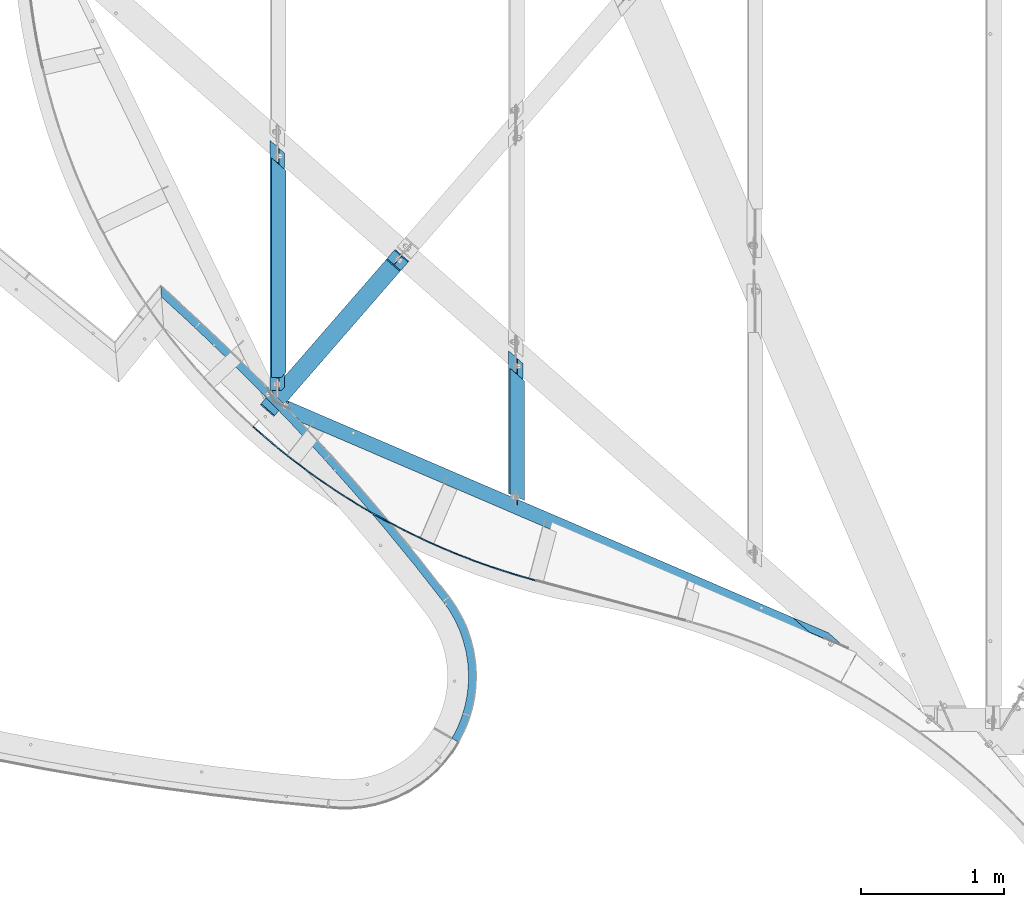
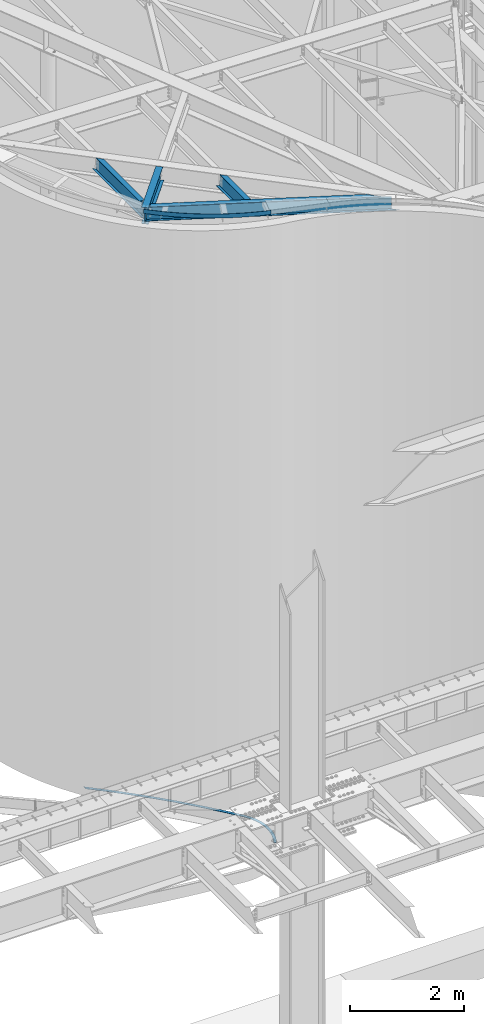
# One storey, part 1148 of 1763: 6 beams, 5 elements without a shape of their own.
"""IFC2X3 building model written with IfcOpenShell, lengths in millimetres."""

from ifc_helpers import new_model, si_unit, frame, origin_with_axes, place, context, subcontext, project, spatial, faceted_brep, material, type_object, element, aggregate, save


model = new_model("IFC2X3")

# Units and contexts
model_context = context("Model", 3, precision=1e-05, world=origin_with_axes())
body_context = subcontext(model_context, "Body", "Model", "MODEL_VIEW")
ifc_project = project(units=[si_unit("LENGTHUNIT", "METRE", prefix="MILLI"), si_unit("AREAUNIT", "SQUARE_METRE"), si_unit("VOLUMEUNIT", "CUBIC_METRE"), si_unit("MASSUNIT", "GRAM", prefix="KILO"), si_unit("TIMEUNIT", "SECOND"), si_unit("PLANEANGLEUNIT", "RADIAN"), si_unit("SOLIDANGLEUNIT", "STERADIAN"), si_unit("THERMODYNAMICTEMPERATUREUNIT", "DEGREE_CELSIUS"), si_unit("LUMINOUSINTENSITYUNIT", "LUMEN")], contexts=[model_context])

# Site, building, storey
site_placement = place(None, origin_with_axes())
site = spatial("IfcSite", under=ifc_project, at=site_placement, CompositionType="ELEMENT")
building_placement = place(site_placement, origin_with_axes())
building = spatial("IfcBuilding", under=site, at=building_placement, Name="Undefined", CompositionType="ELEMENT")
storey_placement = place(building_placement, origin_with_axes())
storey = spatial("IfcBuildingStorey", under=building, at=storey_placement, Name="Undefined", CompositionType="ELEMENT", Elevation=0.0)

# Assembly, beam
assembly_1_placement = place(storey_placement, origin_with_axes())
assembly_1 = element("IfcElementAssembly", 1, at=assembly_1_placement, inside=storey, Name="PLATE", AssemblyPlace="NOTDEFINED", PredefinedType="RIGID_FRAME")
ifc_material_1 = material(Name="STEEL/A36")
beam_type_1 = type_object("IfcBeamType", PredefinedType="NOTDEFINED")
beam_1_placement = place(assembly_1_placement, frame((-46769.9138544958, 57631.4044649229, -3.17499999999491), z_axis=(0.97359968730827, -0.228262237072275, 0.0), x_axis=(0.228262231888325, 0.973599688523656, 0.0)))
beam_1 = element("IfcBeam", 2, at=beam_1_placement, type_object=beam_type_1, material=ifc_material_1, Name="PLATE", context=body_context, shape_type="Brep", body=[
    faceted_brep([(22.7999745803754, -3.17500001063642, -24.5256942961641), (6.15889249815518, -3.175, 30.1478540359603), (-8.84756445884705e-09, 9.69761293490023e-09, 28.5749999999134), (16.6410820689634, -1.58744351885787e-07, -26.0985483375407), (1534.03549039258, 3.18245254706104, -1087.78632156259), (1723.28957115061, 3.18493668133378, -1356.83887718113), (1723.28775202866, -3.16506293471967, -1356.84012894642), (1534.03414568807, -3.16754723696902, -1087.78728830347), (1339.27698435845, 3.17996838873531, -822.69104558714), (1339.27610136085, -3.17003151527805, -822.691708418584), (2473.27803125291, 3.15512548669445, -2441.90225550858), (2634.42711592402, 3.15264106502508, -2730.02312585434), (2567.22163278471, 3.19087219085719, -2708.95851937175), (2473.27419921351, -3.1948729775194, -2441.90445094836), (2634.42275489638, -3.19735699124559, -2730.02550635775), (2423.68593715149, -3.15512548669445, -2470.31439965982), (2423.68976919089, 3.1948729775194, -2470.31220422004), (2555.03166728665, 3.19690478077967, -2705.14034993343), (2555.02490536015, -3.15309338839345, -2705.13823194704), (2306.22559311581, 3.15760988451737, -2157.16352860411), (2306.22228038139, -3.19238893964634, -2157.16551830514), (2257.23001704671, -3.15760988451737, -2186.59134749896), (2257.23332978112, 3.19238893964635, -2186.58935779794), (2133.34075431278, 3.16009425847506, -1875.92788281315), (2133.33795057509, -3.18990487764521, -1875.92964642501), (2084.96249500642, -3.16009425847506, -1906.35885788099), (2084.96529874411, 3.18990487764521, -1906.35709426913), (1954.69694485167, 3.16257860854875, -1598.31476793136), (1954.69463918676, -3.18742079153477, -1598.31628544521), (1906.95653843257, -3.16257860854875, -1629.73595475013), (1906.95884409747, 3.18742079153477, -1629.73443723627), (1770.37004075991, 3.16506293471967, -1324.44209514365), (1770.36822163795, -3.18493668133378, -1324.44334690894), (1580.43698715287, -3.18245254706104, -1054.42715368434), (1580.43833185737, 3.16754723696902, -1054.42618694347), (1384.98160550654, -3.17996838873531, -788.382390558436), (1384.98248850414, 3.17003151527805, -788.381727726999), (80.7582906747048, -3.175, 49.1990007622007), (163.054713896541, -3.175, 62.410724488509), (163.054713896541, 3.175, 62.410724488509), (80.7582906747048, 3.175, 49.1990007622007), (246.21040849424, -3.175, 68.1011879935031), (246.21040849424, 3.175, 68.1011879935031), (329.53942518049, -3.175, 66.2234507831599), (329.53942518049, 3.175, 66.2234507831599), (412.354384938299, -3.175, 56.7930022657092), (412.354384938299, 3.175, 56.7930022657092), (493.972149193702, -3.175, 39.8876339799172), (493.972149193702, 3.175, 39.8876339799172), (573.719455009086, -3.175, 15.6467978945875), (573.719455009086, 3.175, 15.6467978945875), (650.938468812681, -3.175, -15.7295439273657), (650.938468812681, 3.175, -15.7295439273657), (724.99221285159, -3.175, -53.9825688109995), (724.99221285159, 3.175, -53.9825688109995), (795.269819605637, -3.175, -98.7967284912957), (795.269819605637, 3.175, -98.7967284912957), (861.191570818606, -3.175, -149.802352063052), (861.191570818606, 3.175, -149.802352063052), (922.213679579894, -3.175, -206.578695387136), (922.213679579894, 3.175, -206.578695387136), (977.832776009454, -3.175, -268.657411798536), (977.832776009454, 3.175, -268.657411798536), (933.579880992431, 3.175, -304.820981625016), (881.424431994536, 3.175, -246.608181786556), (824.202440168767, 3.175, -193.367552782773), (762.385928323762, 3.175, -145.538275257975), (696.484819351157, 3.175, -103.514891750594), (627.042729884219, 3.175, -67.6440521215482), (554.632486017545, 3.175, -38.2216540480586), (479.85139807863, 3.175, -15.4904021709517), (403.316333429677, 3.175, 0.362193969995133), (325.658627943769, 3.175, 9.20536669759895), (247.51887813073, 3.175, 10.9661688967099), (169.541656872279, 3.175, 5.63007575312804), (92.3701963560234, 3.175, -6.75889543153608), (16.6410820689634, 3.175, -26.0985483375407), (7.52334017306566e-09, 3.175, 28.5749999998952), (1139.09677348819, 3.17748420637537, -561.665643672444), (1184.085527337, 3.17251576962797, -526.421715082877), (1184.08509276175, -3.17748420637537, -526.422055526607), (933.579880992533, -3.175, -304.820981625126), (1139.09633891293, -3.17251576962797, -561.665984116167), (881.424431994536, -3.175, -246.608181786556), (824.202440168767, -3.175, -193.367552782773), (762.385928323762, -3.175, -145.538275257975), (696.484819351157, -3.175, -103.514891750594), (627.042729884219, -3.175, -67.6440521215482), (554.632486017545, -3.175, -38.2216540480586), (479.85139807863, -3.175, -15.4904021709517), (403.316333429677, -3.175, 0.362193969995133), (325.658627943769, -3.175, 9.20536669759895), (247.51887813073, -3.175, 10.9661688967099), (169.541656872279, -3.175, 5.63007575312804), (92.3701963560234, -3.175, -6.75889543153608)], [[[0, 1, 2, 3]], [[4, 5, 6, 7]], [[8, 4, 7, 9]], [[10, 11, 12]], [[10, 13, 14, 11]], [[13, 15, 14]], [[15, 16, 17, 18]], [[15, 18, 14]], [[17, 12, 11, 14, 18]], [[16, 19, 10, 12, 17]], [[20, 13, 10, 19]], [[20, 21, 13]], [[15, 13, 21]], [[22, 16, 15, 21]], [[19, 16, 22, 23]], [[24, 20, 19, 23]], [[24, 25, 20]], [[21, 20, 25]], [[26, 22, 21, 25]], [[23, 22, 26, 27]], [[28, 24, 23, 27]], [[28, 29, 24]], [[25, 24, 29]], [[30, 26, 25, 29]], [[27, 26, 30, 31]], [[32, 28, 27, 31]], [[33, 32, 31, 34]], [[35, 33, 34, 36]], [[35, 9, 33]], [[7, 33, 9]], [[33, 7, 32]], [[6, 32, 7]], [[32, 6, 28]], [[29, 28, 6]], [[5, 30, 29, 6]], [[31, 30, 5, 34]], [[4, 34, 5]], [[34, 4, 36]], [[8, 36, 4]], [[37, 38, 39, 40]], [[38, 41, 42, 39]], [[41, 43, 44, 42]], [[43, 45, 46, 44]], [[45, 47, 48, 46]], [[47, 49, 50, 48]], [[49, 51, 52, 50]], [[51, 53, 54, 52]], [[53, 55, 56, 54]], [[55, 57, 58, 56]], [[57, 59, 60, 58]], [[59, 61, 62, 60]], [[39, 42, 44, 46, 48, 50, 52, 54, 56, 58, 60, 62, 63, 64, 65, 66, 67, 68, 69, 70, 71, 72, 73, 74, 75, 76, 77, 40]], [[63, 62, 78]], [[79, 78, 62]], [[78, 79, 8]], [[36, 8, 79]], [[80, 35, 36, 79]], [[62, 61, 80, 79]], [[61, 81, 80]], [[82, 80, 81]], [[80, 82, 35]], [[9, 35, 82]], [[78, 8, 9, 82]], [[81, 63, 78, 82]], [[64, 63, 81, 83]], [[65, 64, 83, 84]], [[66, 65, 84, 85]], [[67, 66, 85, 86]], [[68, 67, 86, 87]], [[69, 68, 87, 88]], [[70, 69, 88, 89]], [[71, 70, 89, 90]], [[72, 71, 90, 91]], [[73, 72, 91, 92]], [[74, 73, 92, 93]], [[75, 74, 93, 94]], [[76, 75, 94, 0, 3]], [[77, 76, 3, 2]], [[37, 40, 77, 2, 1]], [[94, 93, 92, 91, 90, 89, 88, 87, 86, 85, 84, 83, 81, 61, 59, 57, 55, 53, 51, 49, 47, 45, 43, 41, 38, 37, 1, 0]]]),
])
aggregate(assembly_1, [beam_1])

assembly_2_placement = place(storey_placement, origin_with_axes())
assembly_2 = element("IfcElementAssembly", 3, at=assembly_2_placement, inside=storey, Name="BEAM", AssemblyPlace="NOTDEFINED", PredefinedType="RIGID_FRAME")
beam_type_2 = type_object("IfcBeamType", PredefinedType="NOTDEFINED")
beam_2_placement = place(assembly_2_placement, frame((-46201.735896308, 58755.4652369062, 12670.1493063058), z_axis=(0.0256066577239253, -0.0139122708500072, 0.999575283708039), x_axis=(-0.878314523638845, 0.477194242803782, 0.0291419319880167)))
beam_2 = element("IfcBeam", 4, at=beam_2_placement, type_object=beam_type_2, material=ifc_material_1, Name="PLATE", context=body_context, shape_type="Brep", body=[
    faceted_brep([(-0.743652594275773, 3.08668200803731, -44.4499999999807), (-0.743652593984734, 3.08668200816464, 44.4499999999734), (110.044294424864, 28.3962885762667, 44.4499999998861), (110.044294424573, 28.396288576143, -44.4500000000662), (0.743652594304876, -3.08668200806278, 44.4499999999771), (0.743652594013838, -3.08668200819375, -44.4499999999771), (111.385248448016, 22.1894905041081, -44.4500000000626), (111.385248448321, 22.1894905042318, 44.4499999998898), (221.399589052598, 51.0798453443822, 44.4499999998006), (221.399589052322, 51.0798453442549, -44.4500000001517), (222.593442443249, 44.8430822350056, -44.4500000001481), (222.593442443555, 44.8430822351402, 44.4499999998043), (333.259994112843, 71.1246743295815, 44.449999999717), (333.259994112552, 71.1246743294651, -44.4500000002336), (334.306079618793, 64.8614319492262, -44.4500000002317), (334.306079619098, 64.8614319493499, 44.4499999997224), (445.562990119724, 88.5195723505421, 44.4499999996351), (445.562990119433, 88.5195723504221, -44.4500000003172), (446.460723077224, 82.2333512648656, -44.45000000031), (446.460723077515, 82.2333512649966, 44.4499999996406), (558.245810220615, 103.254817289071, 44.4499999995569), (558.245810220324, 103.254817288936, -44.4500000003973), (558.994688881008, 96.9491309066725, -44.45000000039), (558.994688881314, 96.9491309067926, 44.4499999995624), (671.245475276693, 115.322173523811, 44.4499999994787), (671.245475276402, 115.322173523688, -44.4500000004737), (671.845081086998, 109.000546132596, -44.4500000004664), (671.845081087289, 109.00054613272, 44.4499999994841), (784.498829062562, 124.714896533296, 44.4499999994041), (784.498829062286, 124.714896533173, -44.4500000005482), (784.948826899345, 118.380861330668, -44.4500000005428), (784.948826899621, 118.380861330796, 44.4499999994077), (897.942573564622, 131.427736665395, 44.4499999993295), (897.942573564331, 131.427736665271, -44.4500000006228), (898.242711921179, 125.084833783574, -44.4500000006192), (898.24271192147, 125.084833783698, 44.4499999993332), (1011.5133043586, 135.456942071418, 44.4499999992586), (1011.5133043583, 135.456942071294, -44.4500000006919), (1011.66341548577, 129.108716598817, -44.4500000006883), (1011.66341548607, 129.108716598948, 44.4499999992622), (1125.14754604688, 136.800260803062, 44.4499999991876), (1125.1475460466, 136.800260802935, -44.4500000007647), (1125.14754604659, 130.450260802936, -44.4500000007592), (1125.14754604688, 130.450260803063, 44.4499999991931), (1238.78178773516, 135.456942071007, 44.4499999991203), (1238.78178773486, 135.456942070883, -44.4500000008338), (1238.63167660739, 129.108716598406, -44.4500000008265), (1238.63167660768, 129.108716598537, 44.4499999991258), (1352.35251852912, 131.427736664569, 44.4499999990549), (1352.35251852883, 131.427736664446, -44.4500000008957), (1352.05238017197, 125.084833782741, -44.450000000892), (1352.05238017224, 125.084833782876, 44.4499999990603), (1465.79626303115, 124.714896532067, 44.449999998993), (1465.79626303088, 124.714896531947, -44.4500000009612), (1465.34626519377, 118.380861329431, -44.4500000009557), (1465.34626519408, 118.380861329562, 44.4499999989966), (1579.04961681701, 115.322173522174, 44.4499999989312), (1579.04961681672, 115.32217352205, -44.4500000010212), (1578.45001100609, 109.000546130956, -44.4500000010157), (1578.45001100638, 109.000546131083, 44.4499999989348), (1692.04928187307, 103.254817287012, 44.4499999988711), (1692.04928187277, 103.254817286892, -44.4500000010812), (1691.30040321204, 96.9491309046243, -44.4500000010739), (1691.30040321233, 96.949130904748, 44.4499999988766), (1804.73210197387, 88.5195723480865, 44.4499999988147), (1804.73210197358, 88.5195723479628, -44.4500000011376), (1803.83436901578, 82.23335126241, -44.4500000011321), (1803.83436901607, 82.2333512625373, 44.4499999988202), (1917.03509798071, 71.1246743267184, 44.4499999987602), (1917.03509798042, 71.1246743265947, -44.4500000011922), (1915.98901247414, 64.8614319463668, -44.4500000011867), (1915.98901247444, 64.8614319464905, 44.4499999987675), (2028.89550304088, 51.079845341108, 44.4499999987092), (2028.89550304058, 51.079845340988, -44.4500000012431), (2027.70164964961, 44.8430822317423, -44.4500000012376), (2027.7016496499, 44.8430822318696, 44.4499999987129), (2140.25079766854, 28.3962885725959, 44.4499999986583), (2140.25079766825, 28.396288572465, -44.4500000012958), (2138.90984364478, 22.189490500441, -44.4500000012904), (2138.90984364507, 22.1894905005684, 44.4499999986638), (2251.03874468731, 3.08668200409011, 44.449999998611), (2251.038744687, 3.08668200396642, -44.4500000013413), (2249.551439499, -3.08668201213004, 44.4499999986165), (2249.55143949871, -3.08668201226101, -44.4500000013359)], [[[0, 1, 2, 3]], [[4, 5, 6, 7]], [[5, 4, 1, 0]], [[3, 2, 8, 9]], [[7, 6, 10, 11]], [[9, 8, 12, 13]], [[11, 10, 14, 15]], [[13, 12, 16, 17]], [[15, 14, 18, 19]], [[17, 16, 20, 21]], [[19, 18, 22, 23]], [[21, 20, 24, 25]], [[23, 22, 26, 27]], [[25, 24, 28, 29]], [[27, 26, 30, 31]], [[29, 28, 32, 33]], [[31, 30, 34, 35]], [[33, 32, 36, 37]], [[35, 34, 38, 39]], [[37, 36, 40, 41]], [[39, 38, 42, 43]], [[41, 40, 44, 45]], [[43, 42, 46, 47]], [[45, 44, 48, 49]], [[47, 46, 50, 51]], [[49, 48, 52, 53]], [[51, 50, 54, 55]], [[53, 52, 56, 57]], [[55, 54, 58, 59]], [[57, 56, 60, 61]], [[59, 58, 62, 63]], [[61, 60, 64, 65]], [[63, 62, 66, 67]], [[65, 64, 68, 69]], [[67, 66, 70, 71]], [[69, 68, 72, 73]], [[71, 70, 74, 75]], [[73, 72, 76, 77]], [[75, 74, 78, 79]], [[77, 76, 80, 81]], [[76, 72, 68, 64, 60, 56, 52, 48, 44, 40, 36, 32, 28, 24, 20, 16, 12, 8, 2, 1, 4, 7, 11, 15, 19, 23, 27, 31, 35, 39, 43, 47, 51, 55, 59, 63, 67, 71, 75, 79, 82, 80]], [[79, 78, 83, 82]], [[78, 74, 70, 66, 62, 58, 54, 50, 46, 42, 38, 34, 30, 26, 22, 18, 14, 10, 6, 5, 0, 3, 9, 13, 17, 21, 25, 29, 33, 37, 41, 45, 49, 53, 57, 61, 65, 69, 73, 77, 81, 83]], [[82, 83, 81, 80]]]),
])

assembly_3_placement = place(storey_placement, origin_with_axes())
assembly_3 = element("IfcElementAssembly", 5, at=assembly_3_placement, inside=storey, Name="BEAM", AssemblyPlace="NOTDEFINED", PredefinedType="RIGID_FRAME")
ifc_material_2 = material(Name="STEEL/A992")
beam_type_3 = type_object("IfcBeamType", Name="W14X22", PredefinedType="NOTDEFINED")
beam_3_placement = place(assembly_3_placement, frame((-48079.991922386, 59946.7082810739, 12529.1066598258), z_axis=(0.0172511022173494, 0.0198445932500254, 0.999654236019149), x_axis=(0.655842160335249, 0.75443995938565, -0.0262946460134414)))
beam_3 = element("IfcBeam", 6, at=beam_3_placement, type_object=beam_type_3, material=ifc_material_2, Name="BEAM", ObjectType="W14X22", context=body_context, shape_type="Brep", body=[
    faceted_brep([(1342.53638462444, -63.500000000844, 166.687499999865), (1342.54200190829, -3.17500000086147, 166.687499999816), (1342.54259320133, 3.17499999914435, 166.687499999811), (1342.54821048519, 63.4999999991269, 166.68749999976), (1334.23658565302, 63.4999999991123, 174.624999999754), (1334.22475979227, -63.500000000844, 174.624999999864), (1317.14256125842, -3.17500000083237, 166.687499999818), (1317.14315255146, 3.1749999991589, 166.687499999811), (1301.57934423534, -3.17500000080327, 154.834291783058), (1301.57993552838, 3.174999999188, 154.834307337342), (1298.56088115037, -3.17500000080327, 150.099209506028), (1298.56147244341, 3.174999999188, 150.09922506031), (1298.73444332104, -3.17500000078871, 144.486545285426), (1298.73503461407, 3.17499999921711, 144.486560839709), (1302.03970819279, -3.17500000077416, 139.947013625022), (1302.04029948583, 3.17499999921711, 139.947029179302), (1307.32791149423, -3.17500000078871, 138.058355487427), (1307.32850278726, 3.17499999921711, 138.058371041709), (1421.89722715088, -3.17500000083237, 138.824126773025), (1421.89781844392, 3.1749999991589, 138.824142327307), (1429.1769288343, -3.1750000003376, -138.090483327867), (1429.17752012734, 3.17499999965366, -138.090467773585), (1403.3300335189, -3.1750000003376, -138.26324271675), (1403.33062481194, 3.17499999965366, -138.263227162466), (1397.78114954089, -3.17500000032305, -140.228942113727), (1397.78174083393, 3.17499999968277, -140.228926559445), (1394.44741611587, -3.1750000003085, -145.080777725503), (1394.44800740891, 3.17499999969732, -145.080762171221), (1394.60220520838, -3.17500000029395, -150.965514557867), (1394.60279650141, 3.17499999969732, -150.965499003585), (1398.1863926877, -3.1750000003085, -155.635384734467), (1398.18698398074, 3.17499999969732, -155.635369180187), (1413.23260548103, -3.1750000002794, -166.687499999993), (1413.23319677408, 3.17499999969732, -166.6875), (1429.94989342443, -3.17500000029395, -166.687499999995), (1429.95048471748, 3.17499999969732, -166.687499999998), (1438.01743337284, -63.5000000002765, -174.62499999994), (1438.02957450544, 63.4999999996944, -174.625000000045), (1429.95610200133, 63.4999999996799, -166.687500000049), (1429.94427614058, -63.5000000002765, -166.687499999944), (2.20097717829049e-10, -63.4999999996799, -174.624999999842), (2.03726813197136e-10, -63.4999999996944, -166.687499999845), (3.27418092638254e-10, -3.17499999971187, -166.687499999898), (-3.12866177409887e-10, -3.1750000003085, 166.687499999909), (-4.32919478043914e-10, -63.500000000291, 166.687499999958), (-4.52928361482918e-10, -63.500000000291, 174.624999999953), (-2.00088834390044e-10, 63.4999999996799, 174.624999999845), (-1.81898940354586e-10, 63.4999999996799, 166.687499999851), (-3.01952240988612e-10, 3.17499999969732, 166.687499999904), (3.36513039655983e-10, 3.17500000029395, -166.687499999904), (4.63842297904193e-10, 63.5000000002765, -166.687499999953), (4.80213202536106e-10, 63.500000000291, -174.624999999949), (1413.22698819718, -63.5000000002619, -166.687499999944), (1317.13694397456, -63.5000000008149, 166.687499999869), (1317.14876983531, 63.499999999156, 166.68749999976), (1413.23881405793, 63.4999999996799, -166.687500000051)], [[[0, 1, 2, 3, 4, 5]], [[6, 7, 2, 1]], [[8, 9, 7, 6]], [[10, 11, 9, 8]], [[12, 13, 11, 10]], [[14, 15, 13, 12]], [[16, 17, 15, 14]], [[18, 19, 17, 16]], [[20, 21, 19, 18]], [[22, 23, 21, 20]], [[24, 25, 23, 22]], [[26, 27, 25, 24]], [[28, 29, 27, 26]], [[30, 31, 29, 28]], [[32, 33, 31, 30]], [[34, 35, 33, 32]], [[36, 37, 38, 35, 34, 39]], [[40, 41, 42, 43, 44, 45, 46, 47, 48, 49, 50, 51]], [[52, 41, 40, 36, 39]], [[32, 42, 41, 52, 39, 34]], [[16, 14, 12, 10, 8, 6, 43, 42, 32, 30, 28, 26, 24, 22, 20, 18]], [[53, 44, 43, 6, 1, 0]], [[45, 44, 53, 0, 5]], [[46, 45, 5, 4]], [[54, 47, 46, 4, 3]], [[7, 48, 47, 54, 3, 2]], [[25, 27, 29, 31, 33, 49, 48, 7, 9, 11, 13, 15, 17, 19, 21, 23]], [[55, 50, 49, 33, 35, 38]], [[51, 50, 55, 38, 37]], [[40, 51, 37, 36]]]),
])
aggregate(assembly_3, [beam_3])

assembly_4_placement = place(storey_placement, origin_with_axes())
assembly_4 = element("IfcElementAssembly", 7, at=assembly_4_placement, inside=storey, Name="BEAM", AssemblyPlace="NOTDEFINED", PredefinedType="RIGID_FRAME")
beam_type_4 = type_object("IfcBeamType", Name="W12X16", PredefinedType="NOTDEFINED")
beam_4_placement = place(assembly_4_placement, frame((-46340.5472371989, 59268.7374006593, 12489.8609543434), z_axis=(0.0294363099980619, 0.0, 0.999566657934176), x_axis=(0.0, 1.0, 0.0)))
beam_4 = element("IfcBeam", 8, at=beam_4_placement, type_object=beam_type_4, material=ifc_material_2, Name="BEAM", ObjectType="W12X16", context=body_context, shape_type="Brep", body=[
    faceted_brep([(60.2082465235726, 3.17499999981374, -117.295703353439), (57.4846154797779, -3.17500000019209, -117.295703353453), (18.4558559940342, -3.17500000018481, -117.295703362503), (21.1794870360318, 3.17499999982101, -117.295703362481), (65.4594476598868, 3.17499999982101, -118.248378752771), (62.7358166160921, -3.17500000018481, -118.248378752785), (69.9228235650589, 3.17499999981374, -120.96347732625), (67.1991925212642, -3.17500000019209, -120.963477326266), (72.9287445552836, 3.17499999980646, -125.033659284922), (70.2051135114889, -3.17500000019936, -125.033659284936), (74.0262394452948, 3.17499999979918, -129.848284898691), (71.3026084015, -3.17500000019936, -129.848284898708), (94.6581206680203, 50.7999999997846, -146.050000000005), (94.7383292937739, 50.7999999997774, -152.400000000003), (51.1602325930071, -50.8000000002576, -152.400000000032), (51.0800239672535, -50.8000000002357, -146.050000000032), (71.5072567957395, -3.17500000023574, -146.050000000021), (74.2308878395343, 3.17499999977008, -146.050000000016), (18.0138538379178, 3.17500000020664, 133.323539932177), (15.2902227959203, -3.17499999979918, 133.323539932155), (53.9981486452816, -3.17499999979918, 133.323539941361), (56.7217796890764, 3.17500000019936, 133.323539941379), (59.3234491886469, -3.17499999979191, 134.304423098391), (62.0470802324417, 3.17500000020664, 134.304423098405), (63.826151671492, -3.17499999979918, 137.095555751072), (66.5497827152867, 3.17500000020664, 137.095555751088), (66.8107245840147, -3.17499999979191, 141.265792222921), (69.5343556278094, 3.17500000020664, 141.265792222937), (67.8161415732902, -3.17499999978463, 146.050000000014), (70.539772617085, 3.17500000022119, 146.050000000017), (924.196359461639, -3.17499999978463, 146.050000000014), (882.215980670029, -50.7999999997919, 146.050000000003), (47.388908744826, -50.7999999997919, 146.050000000003), (971.609285035272, 50.800000000243, 152.400000000031), (971.774122092131, 50.8000000002285, 146.05000000003), (90.9670054455491, 50.8000000002285, 146.05000000003), (90.8883252243468, 50.800000000243, 152.400000000031), (882.051143613171, -50.7999999997774, 152.400000000001), (47.31022852358, -50.7999999997774, 152.400000000001), (929.793743300521, 3.17500000022119, 146.050000000017), (924.745963337453, -3.17499999981374, 124.877669717273), (930.343347176364, 3.17500000019209, 124.877669717291), (926.127719666212, -3.17499999982101, 120.094035613532), (931.725103505123, 3.17500000018481, 120.094035613551), (929.818440120158, -3.17499999982829, 116.057677212664), (935.415823959069, 3.17500000017753, 116.057677212684), (935.269915128381, -3.17499999982101, 113.368144205462), (940.8672989673, 3.17500000017753, 113.36814420548), (941.67239743087, -3.17499999982829, 112.424932504502), (947.269781269781, 3.17500000017026, 112.424932504524), (1043.90506163308, 3.17500000017026, 112.424932527798), (1038.30767779981, -3.17499999983556, 112.424932527805), (1045.01735151569, -3.17500000023574, -146.050000000021), (1003.03697276614, -50.8000000002357, -146.050000000032), (1003.20181052305, -50.8000000002576, -152.400000000032), (1092.75995185542, 50.7999999997774, -152.400000000003), (1092.59511409851, 50.7999999997846, -146.050000000005), (1050.61473534896, 3.17499999977008, -146.050000000016)], [[[0, 1, 2, 3]], [[4, 5, 1, 0]], [[6, 7, 5, 4]], [[8, 9, 7, 6]], [[10, 11, 9, 8]], [[12, 13, 14, 15, 16, 11, 10, 17]], [[18, 19, 20, 21]], [[21, 20, 22, 23]], [[23, 22, 24, 25]], [[25, 24, 26, 27]], [[27, 26, 28, 29]], [[30, 31, 32, 28]], [[33, 34, 35, 36]], [[37, 33, 36, 38]], [[31, 37, 38, 32]], [[36, 35, 29, 28, 32, 38]], [[34, 39, 29, 35]], [[33, 37, 31, 30, 40, 41, 39, 34]], [[41, 40, 42, 43]], [[43, 42, 44, 45]], [[45, 44, 46, 47]], [[47, 46, 48, 49]], [[50, 49, 48, 51]], [[52, 53, 54, 55, 56, 57, 50, 51]], [[57, 56, 12, 17]], [[6, 4, 0, 3, 18, 21, 23, 25, 27, 29, 39, 41, 43, 45, 47, 49, 50, 57, 17, 10, 8]], [[19, 18, 3, 2]], [[52, 51, 48, 46, 44, 42, 40, 30, 28, 26, 24, 22, 20, 19, 2, 1, 5, 7, 9, 11, 16]], [[53, 52, 16, 15]], [[54, 53, 15, 14]], [[55, 54, 14, 13]], [[56, 55, 13, 12]]]),
])
aggregate(assembly_4, [beam_4])

# Beam
beam_type_5 = type_object("IfcBeamType", Name="W12X14", PredefinedType="NOTDEFINED")
beam_5_placement = place(assembly_2_placement, frame((-43993.8314317268, 58263.6767394292, 12422.4504535618), z_axis=(0.0268770956565422, -0.0115330758526252, 0.999572213444555), x_axis=(-0.918574538197798, 0.394164214084877, 0.0292470530062977)))
beam_5 = element("IfcBeam", 9, at=beam_5_placement, type_object=beam_type_5, material=ifc_material_2, Name="BEAM", ObjectType="W12X14", context=body_context, shape_type="Brep", body=[
    faceted_brep([(291.665968148023, -2.38125000033324, 117.944475728327), (277.160383048627, 2.3812499996784, 117.944475722665), (45.2236165501745, 2.38124999972206, 117.944475615126), (59.7292016253195, -2.38125000028231, 117.944475620723), (307.16031577067, -2.38125000033324, 118.900146873746), (292.654730671267, 2.38124999967113, 118.900146868082), (320.322773461674, -2.38125000034779, 121.62333236755), (305.817188362271, 2.38124999965657, 121.623332361885), (329.172399313247, -2.38125000036234, 125.704194442811), (314.666814213844, 2.3812499996493, 125.704194437147), (332.377329996452, -2.38125000037689, 130.528565829673), (317.871744897049, 2.3812499996493, 130.528565824006), (480.444272663859, -50.8000000004977, 150.812499999667), (170.991790541026, 50.7999999996828, 150.812499999909), (170.805993852453, 50.7999999996973, 144.462499999911), (318.27944236411, 2.38124999961292, 144.462499999796), (332.785027463622, -2.38125000039145, 144.462499999785), (480.258475975272, -50.8000000004904, 144.462499999669), (52.0512867461875, -2.38124999971478, -144.4625), (199.524735008388, -50.7999999997919, -144.462500000114), (4362.67793783877, -50.8000000006796, -144.462500002483), (4378.20812797094, -2.381250000617, -144.462500002461), (199.338936748376, -50.7999999997846, -150.812500000113), (4362.49213956908, -50.800000000665, -150.812500002483), (-110.113544850974, 50.8000000003958, -150.812499999873), (4395.08007951852, 50.7999999994427, -150.812500002436), (-109.927746590976, 50.8000000003813, -144.462499999876), (4395.26587778822, 50.7999999994354, -144.462500002437), (37.5457016712171, 2.38125000029686, -144.462499999989), (4379.73568765607, 2.38124999938009, -144.462500002459), (4387.62772116308, 2.38124999878346, 125.262362599409), (4386.10016147791, -2.38125000120635, 125.262362598814), (4337.96506565197, 2.38124999880529, 125.262362594014), (4336.43750596426, -2.38125000120635, 125.262362593427), (4332.77542425529, 2.38124999879801, 126.263220231825), (4331.24786456757, -2.38125000120635, 126.263220231236), (4328.40375015138, 2.38124999879074, 129.108042590964), (4326.87619046368, -2.38125000121363, 129.108042590376), (4325.53908640881, 2.38124999879074, 133.34844191857), (4324.01152672111, -2.38125000122091, 133.348441917982), (4324.63294808756, 2.38124999876163, 138.316066069679), (4323.10538839987, -2.38125000122818, 138.316066069092), (4340.52877880291, 50.7999999988097, 150.812499997535), (4307.94083879818, -50.8000000013126, 150.81249999749), (4307.75504038989, -50.8000000012908, 144.462499997493), (4323.28523054837, -2.38125000125001, 144.462499997513), (4324.81279023612, 2.38124999876163, 144.462499997515), (4340.34298039461, 50.7999999988097, 144.462499997537)], [[[0, 1, 2, 3]], [[4, 5, 1, 0]], [[6, 7, 5, 4]], [[8, 9, 7, 6]], [[10, 11, 9, 8]], [[12, 13, 14, 15, 11, 10, 16, 17]], [[18, 19, 20, 21]], [[19, 22, 23, 20]], [[22, 24, 25, 23]], [[24, 26, 27, 25]], [[26, 28, 29, 27]], [[21, 20, 23, 25, 27, 29, 30, 31]], [[30, 32, 33, 31]], [[34, 35, 33, 32]], [[36, 37, 35, 34]], [[38, 39, 37, 36]], [[40, 41, 39, 38]], [[42, 43, 44, 45, 41, 40, 46, 47]], [[44, 43, 12, 17]], [[45, 44, 17, 16]], [[8, 6, 4, 0, 3, 18, 21, 31, 33, 35, 37, 39, 41, 45, 16, 10]], [[28, 26, 24, 22, 19, 18, 3, 2]], [[46, 40, 38, 36, 34, 32, 30, 29, 28, 2, 1, 5, 7, 9, 11, 15]], [[47, 46, 15, 14]], [[42, 47, 14, 13]], [[43, 42, 13, 12]]]),
])

aggregate(assembly_2, [beam_2, beam_5])

# Assembly, beam
assembly_5_placement = place(storey_placement, origin_with_axes())
assembly_5 = element("IfcElementAssembly", 10, at=assembly_5_placement, inside=storey, Name="BEAM", AssemblyPlace="NOTDEFINED", PredefinedType="RIGID_FRAME")
beam_6_placement = place(assembly_5_placement, frame((-48006.3414809328, 60036.5121629541, 12540.5279768686), z_axis=(0.0294363099980619, 0.0, 0.999566657934176), x_axis=(0.0, 1.0, 0.0)))
beam_6 = element("IfcBeam", 11, at=beam_6_placement, type_object=beam_type_5, material=ifc_material_2, Name="BEAM", ObjectType="W12X14", context=body_context, shape_type="Brep", body=[
    faceted_brep([(125.343217050329, -2.38124999983847, 115.756267127164), (125.343217050329, 2.38125000016589, 115.616015924061), (46.1037103288327, 2.38125000016589, 115.616015924061), (46.1037103288327, -2.38124999983847, 115.756267127164), (130.203296568376, -2.3812499998312, 116.723416156108), (130.203296568376, 2.38125000016589, 116.583164953006), (134.323473036529, -2.3812499998312, 119.477623570519), (134.323473036529, 2.38125000016589, 119.337372367418), (137.076486937003, -2.38124999982392, 123.599586258502), (137.076486937003, 2.38125000017317, 123.459335055397), (138.043216859594, -2.38124999980937, 128.461772766494), (138.043216859594, 2.38125000018772, 128.32152156339), (138.043216859594, -19.0210326052184, 150.812500000011), (138.043216859594, 50.8000000002285, 150.812500000029), (138.043216859594, 50.8000000002139, 144.462500000029), (138.043216859594, 2.38125000020955, 144.462500000016), (138.043216859594, -2.38124999978754, 144.462500000016), (138.043216859594, -19.2080340558969, 144.462500000011), (72.636232878569, -50.800000000243, -144.462500000032), (72.4212110963126, -50.8000000002503, -150.812500000035), (1704.38301165288, -50.8000000002503, -150.812500000035), (1704.21817389597, -50.800000000243, -144.462500000032), (1746.89822562467, -2.38125000023138, -144.462500000021), (46.1037103288327, -2.38125000023138, -144.462500000021), (46.1037103288327, -27.7250149028114, -144.462500000027), (46.1037103288327, -27.9120165123313, -150.812500000027), (1793.94115298525, 50.7999999997628, -150.812500000005), (46.1037103288327, 50.7999999997628, -150.812500000005), (1793.77631522834, 50.7999999997701, -144.462500000005), (46.1037103288327, 50.7999999997701, -144.462500000005), (1751.09626349963, 2.38124999976571, -144.462500000018), (46.1037103288327, 2.38124999976571, -144.462500000018), (1744.47017906491, 2.38125000015134, 110.792345423402), (1740.27214118995, -2.38124999984575, 110.792345423406), (1647.8348989511, 2.38125000015862, 110.792345400123), (1643.63686107191, -2.38124999984575, 110.79234540011), (1641.43241659692, 2.38125000015862, 111.735557116923), (1637.23437871774, -2.38124999983847, 111.73555711691), (1635.98094156065, 2.38125000016589, 114.425090166946), (1631.78290368147, -2.3812499998312, 114.425090166935), (1632.29022112008, 2.38125000017317, 118.461448624546), (1628.09218324089, -2.3812499998312, 118.461448624534), (1630.90846485334, 2.38125000017317, 123.245082780426), (1626.71042697415, -2.38124999982392, 123.245082780413), (1673.03774272891, 50.8000000002139, 144.462500000029), (1672.87290578378, 50.8000000002285, 150.812500000029), (1583.31476436168, -50.7999999997919, 150.812500000002), (1583.47960130681, -50.7999999997992, 144.4625), (1626.15965307828, -2.38124999978754, 144.462500000016), (1630.35769095744, 2.38125000020955, 144.462500000016), (174.583919520046, -50.7999999997919, 150.812500000002), (174.368897920343, -50.7999999997992, 144.4625)], [[[0, 1, 2, 3]], [[4, 5, 1, 0]], [[6, 7, 5, 4]], [[8, 9, 7, 6]], [[10, 11, 9, 8]], [[12, 13, 14, 15, 11, 10, 16, 17]], [[18, 19, 20, 21]], [[18, 21, 22, 23, 24]], [[19, 18, 24, 25]], [[26, 20, 19, 25, 27]], [[28, 26, 27, 29]], [[30, 28, 29, 31]], [[22, 21, 20, 26, 28, 30, 32, 33]], [[32, 34, 35, 33]], [[36, 37, 35, 34]], [[38, 39, 37, 36]], [[40, 41, 39, 38]], [[42, 43, 41, 40]], [[44, 45, 46, 47, 48, 43, 42, 49]], [[47, 46, 50, 51]], [[51, 50, 12, 17]], [[48, 47, 51, 17, 16]], [[8, 6, 4, 0, 3, 23, 22, 33, 35, 37, 39, 41, 43, 48, 16, 10]], [[31, 29, 27, 25, 24, 23, 3, 2]], [[49, 42, 40, 38, 36, 34, 32, 30, 31, 2, 1, 5, 7, 9, 11, 15]], [[44, 49, 15, 14]], [[45, 44, 14, 13]], [[50, 46, 45, 13, 12]]]),
])
aggregate(assembly_5, [beam_6])

save(model, "model.ifc")
